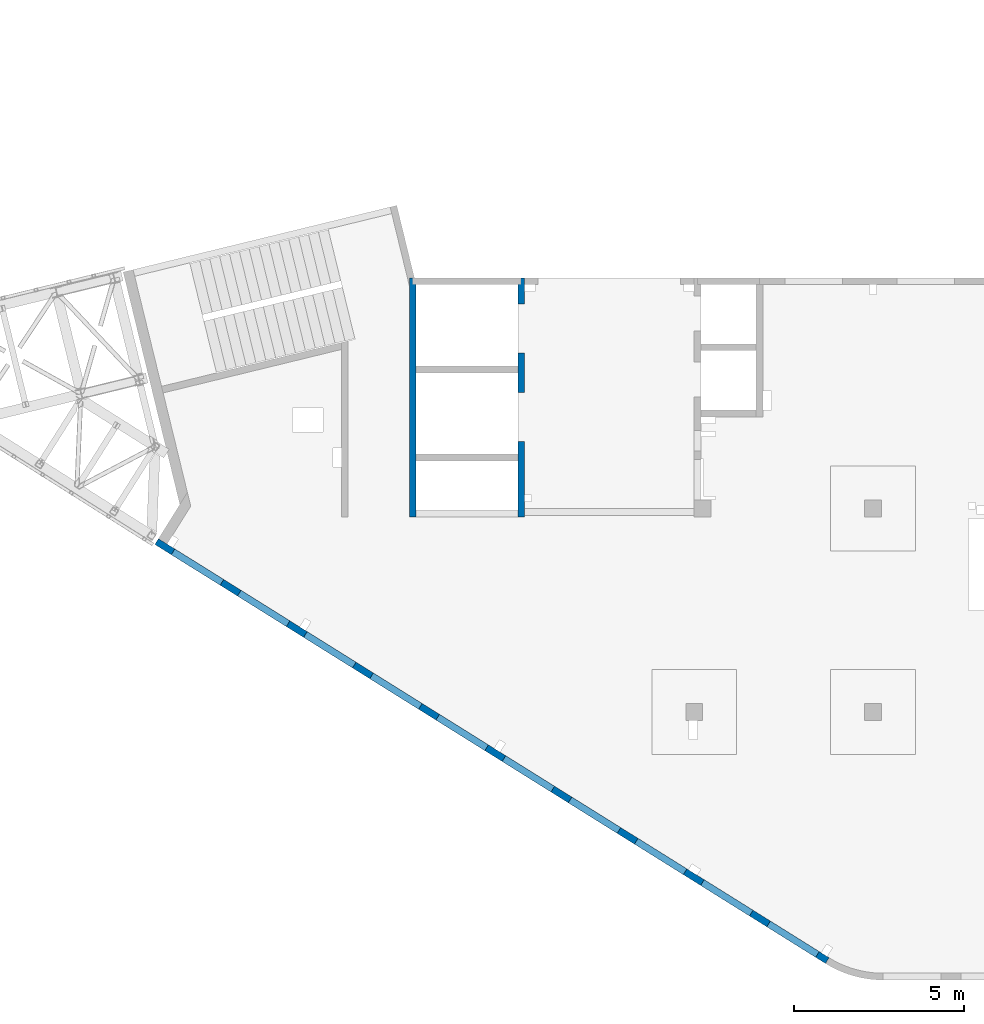
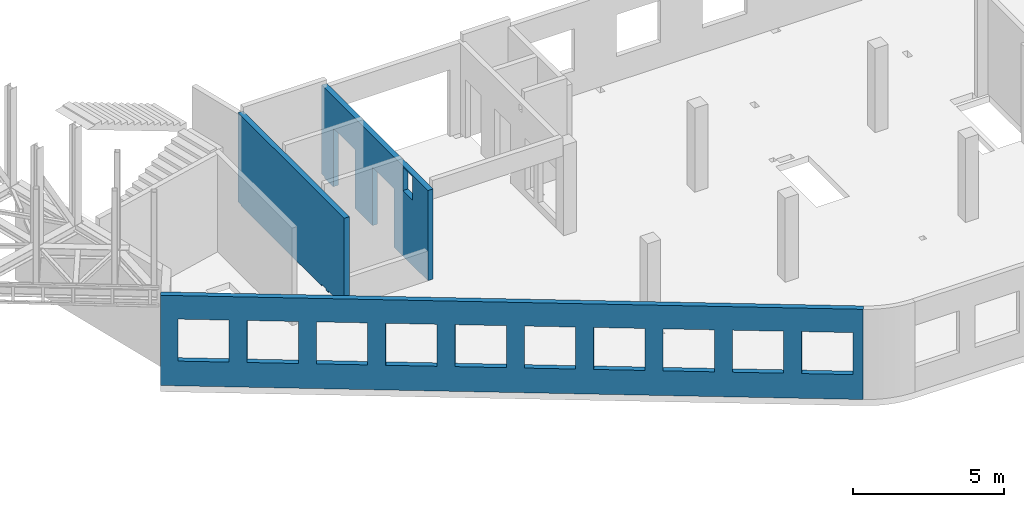
# One storey, part 89 of 93: 3 walls, 15 openings.
"""IFC4 building model written with IfcOpenShell, lengths in millimetres."""

from ifc_helpers import new_model, entity, si_unit, converted_unit, derived_unit, direction, frame, origin, place, context, subcontext, project, spatial, indexed_curve, outline, extrude, polygons, material, type_object, element, save


model = new_model("IFC4")

# Units and contexts
model_context = context("Model", 3, precision=0.01, world=origin(), true_north=direction((6.12303176911189e-17, 1.0)))
plan_context = context("Plan", 3, precision=0.01, world=origin(), true_north=direction((6.12303176911189e-17, 1.0)))
body_context = subcontext(model_context, "Body", "Model", "MODEL_VIEW")
ifc_project = project(units=[si_unit("LENGTHUNIT", "METRE", prefix="MILLI"), si_unit("AREAUNIT", "SQUARE_METRE"), si_unit("VOLUMEUNIT", "CUBIC_METRE"), converted_unit("PLANEANGLEUNIT", "DEGREE", entity("IfcRatioMeasure", 0.0174532925199433), si_unit("PLANEANGLEUNIT", "RADIAN"), dimensions=[0, 0, 0, 0, 0, 0, 0]), si_unit("MASSUNIT", "GRAM", prefix="KILO"), derived_unit("MASSDENSITYUNIT", [(si_unit("MASSUNIT", "GRAM", prefix="KILO"), 1), (si_unit("LENGTHUNIT", "METRE"), -3)]), derived_unit("MOMENTOFINERTIAUNIT", [(si_unit("LENGTHUNIT", "METRE"), 4)]), si_unit("TIMEUNIT", "SECOND"), si_unit("FREQUENCYUNIT", "HERTZ"), si_unit("THERMODYNAMICTEMPERATUREUNIT", "DEGREE_CELSIUS"), derived_unit("THERMALTRANSMITTANCEUNIT", [(si_unit("MASSUNIT", "GRAM", prefix="KILO"), 1), (si_unit("THERMODYNAMICTEMPERATUREUNIT", "KELVIN"), -1), (si_unit("TIMEUNIT", "SECOND"), -3)]), derived_unit("VOLUMETRICFLOWRATEUNIT", [(si_unit("LENGTHUNIT", "METRE"), 3), (si_unit("TIMEUNIT", "SECOND"), -1)]), derived_unit("MASSFLOWRATEUNIT", [(si_unit("MASSUNIT", "GRAM", prefix="KILO"), 1), (si_unit("TIMEUNIT", "SECOND"), -1)]), derived_unit("ROTATIONALFREQUENCYUNIT", [(si_unit("TIMEUNIT", "SECOND"), -1)]), si_unit("ELECTRICCURRENTUNIT", "AMPERE"), si_unit("ELECTRICVOLTAGEUNIT", "VOLT"), si_unit("POWERUNIT", "WATT"), si_unit("FORCEUNIT", "NEWTON", prefix="KILO"), si_unit("ILLUMINANCEUNIT", "LUX"), si_unit("LUMINOUSFLUXUNIT", "LUMEN"), si_unit("LUMINOUSINTENSITYUNIT", "CANDELA"), derived_unit("USERDEFINED", [(si_unit("MASSUNIT", "GRAM", prefix="KILO"), -1), (si_unit("LENGTHUNIT", "METRE"), -2), (si_unit("TIMEUNIT", "SECOND"), 3), (si_unit("LUMINOUSFLUXUNIT", "LUMEN"), 1)]), derived_unit("LINEARVELOCITYUNIT", [(si_unit("LENGTHUNIT", "METRE"), 1), (si_unit("TIMEUNIT", "SECOND"), -1)]), si_unit("PRESSUREUNIT", "PASCAL"), derived_unit("USERDEFINED", [(si_unit("LENGTHUNIT", "METRE"), -2), (si_unit("MASSUNIT", "GRAM", prefix="KILO"), 1), (si_unit("TIMEUNIT", "SECOND"), -2)]), derived_unit("LINEARFORCEUNIT", [(si_unit("MASSUNIT", "GRAM", prefix="KILO"), 1), (si_unit("LENGTHUNIT", "METRE"), 1), (si_unit("TIMEUNIT", "SECOND"), -2), (si_unit("LENGTHUNIT", "METRE"), -1)]), derived_unit("PLANARFORCEUNIT", [(si_unit("MASSUNIT", "GRAM", prefix="KILO"), 1), (si_unit("LENGTHUNIT", "METRE"), 1), (si_unit("TIMEUNIT", "SECOND"), -2), (si_unit("LENGTHUNIT", "METRE"), -2)])], contexts=[model_context, plan_context])

# Site, building, storey
site_placement = place(None, origin())
site = spatial("IfcSite", under=ifc_project, at=site_placement, CompositionType="ELEMENT")
building_placement = place(site_placement, origin())
building = spatial("IfcBuilding", under=site, at=building_placement, CompositionType="ELEMENT")
storey_placement = place(building_placement, frame((0.0, 0.0, 15900.0)))
storey = spatial("IfcBuildingStorey", under=building, at=storey_placement, CompositionType="ELEMENT", Elevation=15900.0)

# Wall, openings
ifc_material = material()
wall_type = type_object("IfcWallType", PredefinedType="STANDARD")
wall_1_placement = place(storey_placement, frame((19822.3508929728, 371.159406986362, -150.0), z_axis=(0.0, 0.0, 1.0), x_axis=(-0.848052743777574, 0.529911826412025, 0.0)))
wall_1 = element("IfcWall", 1, at=wall_1_placement, inside=storey, type_object=wall_type, material=ifc_material, PredefinedType="NOTDEFINED", context=body_context, shape_type="Tessellation", body=[
    polygons([(-1.48894230278529e-12, -99.9999999999978, -2.16573425859679e-12), (23011.6394501553, -99.9999999999989, 0.0), (23311.6394501553, -99.9999999999989, -2.16573425859679e-12), (23311.6394501553, -99.9999999999989, 2400.0), (23311.6394501553, -99.9999999999989, 3300.0), (23311.6394501553, -99.9999999999989, 3650.0), (23011.6394501553, -99.9999999999989, 3650.0), (-1.48894230278529e-12, -99.9999999999978, 3650.0), (341.63903172165, -99.9999999999988, 2700.0), (2041.63903172165, -99.9999999999981, 2700.0), (2041.63903172165, -99.9999999999981, 1000.00000000001), (341.63903172165, -99.9999999999988, 1000.00000000001), (2641.63903172165, -99.9999999999995, 2700.0), (4341.63903172165, -99.9999999999992, 2700.0), (4341.63903172165, -99.9999999999992, 1000.00000000001), (2641.63903172165, -99.9999999999995, 1000.00000000001), (4941.63903172166, -100.0, 2700.0), (6641.63903172166, -99.9999999999984, 2700.0), (6641.63903172166, -99.9999999999984, 1000.00000000001), (4941.63903172166, -100.0, 1000.00000000001), (7241.63903172167, -99.9999999999984, 2700.0), (8941.63903172167, -100.0, 2700.0), (8941.63903172167, -100.0, 1000.00000000001), (7241.63903172167, -99.9999999999984, 1000.00000000001), (9541.63903172167, -100.0, 2700.0), (11241.6390317217, -99.9999999999989, 2700.0), (11241.6390317217, -99.9999999999989, 1000.00000000001), (9541.63903172167, -100.0, 1000.00000000001), (11841.6390317217, -100.0, 2700.0), (13541.6390317217, -100.0, 2700.0), (13541.6390317217, -100.0, 1000.00000000001), (11841.6390317217, -100.0, 1000.00000000001), (14141.6390317217, -100.0, 2700.0), (15841.6390317217, -100.0, 2700.0), (15841.6390317217, -100.0, 1000.00000000001), (14141.6390317217, -100.0, 1000.00000000001), (16441.6390317217, -99.9999999999989, 2700.0), (18141.6390317217, -99.9999999999989, 2700.0), (18141.6390317217, -99.9999999999989, 1000.00000000001), (16441.6390317217, -99.9999999999989, 1000.00000000001), (18741.6390317217, -100.0, 2700.0), (20441.6390317217, -99.9999999999989, 2700.0), (20441.6390317217, -99.9999999999989, 1000.00000000001), (18741.6390317217, -100.0, 1000.00000000001), (21041.6390317217, -99.9999999999989, 2700.0), (22741.6390317217, -100.000000000001, 2700.0), (22741.6390317217, -100.000000000001, 1000.00000000001), (21041.6390317217, -99.9999999999989, 1000.00000000001), (23311.6394501553, 99.9999999999989, -2.16573425859679e-12), (-2.26725305196851e-12, 100.000000000001, -2.16573425859679e-12), (-2.26725305196851e-12, 100.000000000001, 3650.0), (23311.6394501553, 100.000000000001, 3650.0), (23311.6394501553, 100.000000000001, 3300.0), (23311.6394501553, 100.000000000001, 2400.0), (2041.63903172165, 100.000000000323, 2700.0), (341.63903172165, 100.000000000321, 2700.0), (341.63903172165, 100.000000000321, 1000.00000000001), (2041.63903172165, 100.000000000323, 1000.00000000001), (4341.63903172165, 100.000000000322, 2700.0), (2641.63903172165, 100.00000000032, 2700.0), (2641.63903172165, 100.00000000032, 1000.00000000001), (4341.63903172165, 100.000000000322, 1000.00000000001), (6641.63903172166, 100.000000000322, 2700.0), (4941.63903172166, 100.000000000321, 2700.0), (4941.63903172166, 100.000000000321, 1000.00000000001), (6641.63903172166, 100.000000000322, 1000.00000000001), (8941.63903172166, 100.000000000321, 2700.0), (7241.63903172167, 100.000000000322, 2700.0), (7241.63903172167, 100.000000000322, 1000.00000000001), (8941.63903172166, 100.000000000321, 1000.00000000001), (11241.6390317217, 100.000000000323, 2700.0), (9541.63903172167, 100.000000000321, 2700.0), (9541.63903172167, 100.000000000321, 1000.00000000001), (11241.6390317217, 100.000000000323, 1000.00000000001), (13541.6390317217, 100.000000000319, 2700.0), (11841.6390317217, 100.000000000323, 2700.0), (11841.6390317217, 100.000000000323, 1000.00000000001), (13541.6390317217, 100.000000000319, 1000.00000000001), (15841.6390317217, 100.000000000322, 2700.0), (14141.6390317217, 100.000000000322, 2700.0), (14141.6390317217, 100.000000000322, 1000.00000000001), (15841.6390317217, 100.000000000322, 1000.00000000001), (18141.6390317217, 100.000000000322, 2700.0), (16441.6390317217, 100.000000000322, 2700.0), (16441.6390317217, 100.000000000322, 1000.00000000001), (18141.6390317217, 100.000000000322, 1000.00000000001), (20441.6390317217, 100.000000000322, 2700.0), (18741.6390317217, 100.000000000319, 2700.0), (18741.6390317217, 100.000000000319, 1000.00000000001), (20441.6390317217, 100.000000000322, 1000.00000000001), (22741.6390317217, 100.000000000319, 2700.0), (21041.6390317217, 100.000000000321, 2700.0), (21041.6390317217, 100.000000000323, 1000.00000000001), (22741.6390317217, 100.000000000319, 1000.00000000001)], [[[1, 2, 3, 4, 5, 6, 7, 8], [9, 10, 11, 12], [13, 14, 15, 16], [17, 18, 19, 20], [21, 22, 23, 24], [25, 26, 27, 28], [29, 30, 31, 32], [33, 34, 35, 36], [37, 38, 39, 40], [41, 42, 43, 44], [45, 46, 47, 48]], [[49, 50, 51, 52, 53, 54], [55, 56, 57, 58], [59, 60, 61, 62], [63, 64, 65, 66], [67, 68, 69, 70], [71, 72, 73, 74], [75, 76, 77, 78], [79, 80, 81, 82], [83, 84, 85, 86], [87, 88, 89, 90], [91, 92, 93, 94]], [[3, 2, 1, 50, 49]], [[8, 7, 6, 52, 51]], [[1, 8, 51, 50]], [[3, 49, 54, 53, 52, 6, 5, 4]], [[56, 55, 10, 9]], [[56, 9, 12, 57]], [[57, 12, 11, 58]], [[10, 55, 58, 11]], [[60, 59, 14, 13]], [[60, 13, 16, 61]], [[61, 16, 15, 62]], [[14, 59, 62, 15]], [[64, 63, 18, 17]], [[64, 17, 20, 65]], [[65, 20, 19, 66]], [[18, 63, 66, 19]], [[68, 67, 22, 21]], [[68, 21, 24, 69]], [[69, 24, 23, 70]], [[22, 67, 70, 23]], [[72, 71, 26, 25]], [[72, 25, 28, 73]], [[73, 28, 27, 74]], [[26, 71, 74, 27]], [[76, 75, 30, 29]], [[76, 29, 32, 77]], [[77, 32, 31, 78]], [[30, 75, 78, 31]], [[80, 79, 34, 33]], [[80, 33, 36, 81]], [[81, 36, 35, 82]], [[34, 79, 82, 35]], [[84, 83, 38, 37]], [[84, 37, 40, 85]], [[85, 40, 39, 86]], [[38, 83, 86, 39]], [[88, 87, 42, 41]], [[88, 41, 44, 89]], [[89, 44, 43, 90]], [[42, 87, 90, 43]], [[92, 91, 46, 45]], [[92, 45, 48, 93]], [[93, 48, 47, 94]], [[46, 91, 94, 47]]], closed=True),
])
opening_1_placement = place(wall_1_placement, frame((16613.7173036613, 10818.8609189489, 150.0), z_axis=(0.0, 0.0, 1.0), x_axis=(-0.848052743777574, -0.529911826412026, 0.0)))
element("IfcOpeningElement", 2, at=opening_1_placement, cuts=wall_1, PredefinedType="OPENING", context=body_context, shape_type="SweptSolid", body=[
    extrude(outline(indexed_curve([(-849.999999999993, -850.0), (849.999999999995, -850.0), (849.999999999995, 850.0), (-849.999999999993, 850.0), (-849.999999999993, -850.0)], self_intersect=False)), frame((1310.07752897417, 12056.6031038165, 1700.0), z_axis=(-0.529911826412026, -0.848052743777574, 0.0), x_axis=(0.0, 0.0, -1.0)), (0.0, 0.0, 1.0), 200.000000000964),
])
opening_2_placement = place(wall_1_placement, frame((16613.7173036613, 10818.8609189489, 150.0), z_axis=(0.0, 0.0, 1.0), x_axis=(-0.848052743777574, -0.529911826412026, 0.0)))
element("IfcOpeningElement", 3, at=opening_2_placement, cuts=wall_1, PredefinedType="OPENING", context=body_context, shape_type="SweptSolid", body=[
    extrude(outline(indexed_curve([(-849.999999999993, -850.0), (849.999999999995, -850.0), (849.999999999995, 850.0), (-849.999999999993, 850.0), (-849.999999999993, -850.0)], self_intersect=False)), frame((3260.5988396626, 10837.8059030689, 1700.0), z_axis=(-0.529911826412026, -0.848052743777574, 0.0), x_axis=(0.0, 0.0, -1.0)), (0.0, 0.0, 1.0), 200.000000000964),
])
opening_3_placement = place(wall_1_placement, frame((16613.7173036613, 10818.8609189489, 150.0), z_axis=(0.0, 0.0, 1.0), x_axis=(-0.848052743777574, -0.529911826412026, 0.0)))
element("IfcOpeningElement", 4, at=opening_3_placement, cuts=wall_1, PredefinedType="OPENING", context=body_context, shape_type="SweptSolid", body=[
    extrude(outline(indexed_curve([(-849.999999999993, -850.0), (849.999999999995, -850.0), (849.999999999995, 850.0), (-849.999999999993, 850.0), (-849.999999999993, -850.0)], self_intersect=False)), frame((5211.12015035101, 9619.00870232123, 1700.0), z_axis=(-0.529911826412025, -0.848052743777574, 0.0), x_axis=(0.0, 0.0, -1.0)), (0.0, 0.0, 1.0), 200.000000000962),
])
opening_4_placement = place(wall_1_placement, frame((16613.7173036613, 10818.8609189489, 150.0), z_axis=(0.0, 0.0, 1.0), x_axis=(-0.848052743777574, -0.529911826412026, 0.0)))
element("IfcOpeningElement", 5, at=opening_4_placement, cuts=wall_1, PredefinedType="OPENING", context=body_context, shape_type="SweptSolid", body=[
    extrude(outline(indexed_curve([(-849.999999999993, -849.999999999999), (849.999999999995, -849.999999999999), (849.999999999995, 850.0), (-849.999999999993, 850.0), (-849.999999999993, -849.999999999999)], self_intersect=False)), frame((7161.64146103944, 8400.21150157357, 1700.0), z_axis=(-0.529911826412026, -0.848052743777574, 0.0), x_axis=(0.0, 0.0, -1.0)), (0.0, 0.0, 1.0), 200.000000000962),
])
opening_5_placement = place(wall_1_placement, frame((16613.7173036613, 10818.8609189489, 150.0), z_axis=(0.0, 0.0, 1.0), x_axis=(-0.848052743777574, -0.529911826412026, 0.0)))
element("IfcOpeningElement", 6, at=opening_5_placement, cuts=wall_1, PredefinedType="OPENING", context=body_context, shape_type="SweptSolid", body=[
    extrude(outline(indexed_curve([(-849.999999999993, -849.999999999999), (849.999999999995, -849.999999999999), (849.999999999995, 850.0), (-849.999999999993, 850.0), (-849.999999999993, -849.999999999999)], self_intersect=False)), frame((9112.16277172786, 7181.41430082591, 1700.0), z_axis=(-0.529911826412026, -0.848052743777574, 0.0), x_axis=(0.0, 0.0, -1.0)), (0.0, 0.0, 1.0), 200.000000000962),
])
opening_6_placement = place(wall_1_placement, frame((16613.7173036613, 10818.8609189489, 150.0), z_axis=(0.0, 0.0, 1.0), x_axis=(-0.848052743777574, -0.529911826412026, 0.0)))
element("IfcOpeningElement", 7, at=opening_6_placement, cuts=wall_1, PredefinedType="OPENING", context=body_context, shape_type="SweptSolid", body=[
    extrude(outline(indexed_curve([(-849.999999999993, -850.0), (849.999999999995, -850.0), (849.999999999995, 850.0), (-849.999999999993, 850.0), (-849.999999999993, -850.0)], self_intersect=False)), frame((11062.6840824163, 5962.61710007824, 1700.0), z_axis=(-0.529911826412025, -0.848052743777574, 0.0), x_axis=(0.0, 0.0, -1.0)), (0.0, 0.0, 1.0), 200.000000000964),
])
opening_7_placement = place(wall_1_placement, frame((16613.7173036613, 10818.8609189489, 150.0), z_axis=(0.0, 0.0, 1.0), x_axis=(-0.848052743777574, -0.529911826412026, 0.0)))
element("IfcOpeningElement", 8, at=opening_7_placement, cuts=wall_1, PredefinedType="OPENING", context=body_context, shape_type="SweptSolid", body=[
    extrude(outline(indexed_curve([(-849.999999999993, -850.0), (849.999999999995, -850.0), (849.999999999995, 850.0), (-849.999999999993, 850.0), (-849.999999999993, -850.0)], self_intersect=False)), frame((13013.2053931047, 4743.81989933058, 1700.0), z_axis=(-0.529911826412025, -0.848052743777574, 0.0), x_axis=(0.0, 0.0, -1.0)), (0.0, 0.0, 1.0), 200.000000000959),
])
opening_8_placement = place(wall_1_placement, frame((16613.7173036613, 10818.8609189489, 150.0), z_axis=(0.0, 0.0, 1.0), x_axis=(-0.848052743777574, -0.529911826412026, 0.0)))
element("IfcOpeningElement", 9, at=opening_8_placement, cuts=wall_1, PredefinedType="OPENING", context=body_context, shape_type="SweptSolid", body=[
    extrude(outline(indexed_curve([(-849.999999999993, -850.000000000002), (849.999999999995, -850.000000000002), (849.999999999995, 849.999999999998), (-849.999999999993, 849.999999999998), (-849.999999999993, -850.000000000002)], self_intersect=False)), frame((14963.7267037931, 3525.02269858292, 1700.0), z_axis=(-0.529911826412025, -0.848052743777574, 0.0), x_axis=(0.0, 0.0, -1.0)), (0.0, 0.0, 1.0), 200.000000000962),
])
opening_9_placement = place(wall_1_placement, frame((16613.7173036613, 10818.8609189489, 150.0), z_axis=(0.0, 0.0, 1.0), x_axis=(-0.848052743777574, -0.529911826412026, 0.0)))
element("IfcOpeningElement", 10, at=opening_9_placement, cuts=wall_1, PredefinedType="OPENING", context=body_context, shape_type="SweptSolid", body=[
    extrude(outline(indexed_curve([(-849.999999999993, -850.0), (849.999999999995, -850.0), (849.999999999995, 850.0), (-849.999999999993, 850.0), (-849.999999999993, -850.0)], self_intersect=False)), frame((16914.2480144816, 2306.22549783526, 1700.0), z_axis=(-0.529911826412025, -0.848052743777574, 0.0), x_axis=(0.0, 0.0, -1.0)), (0.0, 0.0, 1.0), 200.000000000962),
])
opening_10_placement = place(wall_1_placement, frame((16613.7173036613, 10818.8609189489, 150.0), z_axis=(0.0, 0.0, 1.0), x_axis=(-0.848052743777574, -0.529911826412026, 0.0)))
element("IfcOpeningElement", 11, at=opening_10_placement, cuts=wall_1, PredefinedType="OPENING", context=body_context, shape_type="SweptSolid", body=[
    extrude(outline(indexed_curve([(-849.999999999993, -850.0), (849.999999999995, -850.0), (849.999999999995, 850.0), (-849.999999999993, 850.0), (-849.999999999993, -850.0)], self_intersect=False)), frame((18864.76932517, 1087.4282970876, 1700.0), z_axis=(-0.529911826412025, -0.848052743777574, 0.0), x_axis=(0.0, 0.0, -1.0)), (0.0, 0.0, 1.0), 200.000000000966),
])

wall_2_placement = place(storey_placement, frame((7600.0002685547, 20499.9998657227, -150.0), z_axis=(0.0, 0.0, 1.0), x_axis=(0.0, -1.0, 0.0)))
wall_2 = element("IfcWall", 12, at=wall_2_placement, inside=storey, type_object=wall_type, material=ifc_material, PredefinedType="NOTDEFINED", context=body_context, shape_type="Tessellation", body=[
    polygons([(7050.00063936678, -99.9999999999996, 3650.0), (226.500105821614, -99.9999999999996, 3650.0), (0.0, -100.000000000001, 3650.0), (0.0, -100.000000000001, 49.9999999999995), (200.000000000002, -100.000000000001, 49.9999999999995), (200.000000000002, -100.000000000001, -2.16573425859679e-12), (226.50010582161, -99.9999999999996, 0.0), (5545.0, -100.000000000001, -2.16573425859679e-12), (5545.0, -100.000000000001, 59.9999999999972), (5855.0, -100.0, 59.9999999999972), (5855.0, -100.0, -2.16573425859679e-12), (5985.0, -100.0, -2.16573425859679e-12), (5985.0, -100.0, 59.9999999999972), (6294.99999999999, -99.9999999999997, 59.9999999999972), (6294.99999999999, -99.9999999999997, -2.16573425859679e-12), (7050.00063936678, -99.9999999999996, -2.16573425859679e-12), (0.0, 100.0, 3650.0), (6850.00063936679, 100.0, 3650.0), (7050.00063936678, 99.9999999999993, 3650.0), (7050.00063936678, 100.0, 1200.0), (7050.00063936678, 99.9999999999993, -2.16573425859679e-12), (6850.0006393668, 100.0, 0.0), (6294.99999999999, 100.0, -2.16573425859679e-12), (6294.99999999999, 100.000000000321, 59.9999999999972), (5985.0, 100.000000000321, 59.9999999999972), (5985.0, 100.000000000001, -2.16573425859679e-12), (5855.0, 100.000000000001, -2.16573425859679e-12), (5855.0, 100.000000000321, 59.9999999999972), (5545.0, 100.000000000321, 59.9999999999972), (5545.0, 100.0, -2.16573425859679e-12), (200.000000000002, 100.0, -2.16573425859679e-12), (200.000000000002, 100.0, 49.9999999999995), (0.0, 100.0, 49.9999999999995), (200.000000000002, -6.87656940234796e-13, 0.0), (0.0, 50.6443876577722, 3650.0)], [[[1, 2, 3, 4, 5, 6, 7, 8, 9, 10, 11, 12, 13, 14, 15, 16]], [[17, 18, 19, 20, 21, 22, 23, 24, 25, 26, 27, 28, 29, 30, 31, 32, 33]], [[6, 34, 31, 30, 8, 7]], [[3, 2, 1, 19, 18, 17, 35]], [[6, 5, 32, 31, 34]], [[4, 3, 35, 17, 33]], [[13, 25, 24, 14]], [[25, 13, 12, 26]], [[14, 24, 23, 15]], [[9, 29, 28, 10]], [[29, 9, 8, 30]], [[10, 28, 27, 11]], [[1, 16, 21, 20, 19]], [[33, 32, 5, 4]], [[16, 15, 23, 22, 21]], [[26, 12, 11, 27]]], closed=True),
])
opening_11_placement = place(wall_2_placement, origin())
element("IfcOpeningElement", 13, at=opening_11_placement, cuts=wall_2, PredefinedType="OPENING", context=body_context, shape_type="SweptSolid", body=[
    extrude(outline(indexed_curve([(-154.999999999995, -154.999999999999), (154.999999999991, -154.999999999999), (154.999999999991, 154.999999999999), (-154.999999999995, 154.999999999999), (-154.999999999995, -154.999999999999)], self_intersect=False)), frame((6140.0, -100.0, -95.0), z_axis=(0.0, 1.0, 0.0), x_axis=(0.0, 0.0, -1.0)), (0.0, 0.0, 1.0), 200.000000000962),
])
opening_12_placement = place(wall_2_placement, origin())
element("IfcOpeningElement", 14, at=opening_12_placement, cuts=wall_2, PredefinedType="OPENING", context=body_context, shape_type="SweptSolid", body=[
    extrude(outline(indexed_curve([(-154.999999999995, -154.999999999999), (154.999999999991, -154.999999999999), (154.999999999991, 154.999999999999), (-154.999999999995, 154.999999999999), (-154.999999999995, -154.999999999999)], self_intersect=False)), frame((5700.0, -100.0, -95.0), z_axis=(0.0, 1.0, 0.0), x_axis=(0.0, 0.0, -1.0)), (0.0, 0.0, 1.0), 200.000000000962),
])

wall_3_placement = place(storey_placement, frame((10800.0002685547, 20499.9998657227, -150.0), z_axis=(0.0, 0.0, 1.0), x_axis=(0.0, -1.0, 0.0)))
wall_3 = element("IfcWall", 15, at=wall_3_placement, inside=storey, type_object=wall_type, material=ifc_material, PredefinedType="NOTDEFINED", context=body_context, shape_type="Tessellation", body=[
    polygons([(5400.00000000002, -99.999999999999, 3600.0), (6050.00000000002, -99.9999999999979, 3600.0), (6050.00000000002, -99.9999999999979, 2650.00000000002), (5400.00000000002, -99.999999999999, 2650.00000000002), (7050.00063936681, -99.9999999999985, 3650.0), (6850.00063936682, -99.9999999999988, 3650.0), (200.000000000028, -99.9999999999985, 3650.0), (0.0, -99.9999999999988, 3650.0), (0.0, -99.9999999999988, 49.9999999999995), (200.000000000028, -99.9999999999985, 49.9999999999995), (200.000000000028, -99.9999999999985, -2.16573425859679e-12), (780.000000000018, -99.9999999999976, -2.16573425859679e-12), (780.000000000018, -99.9999999999976, 2369.99999999805), (2220.00000000001, -99.9999999999975, 2369.99999999804), (2220.00000000001, -99.9999999999975, -2.16573425859679e-12), (3380.00000000002, -99.9999999999978, -2.16573425859679e-12), (3380.00000000002, -99.9999999999978, 2369.99999999805), (4820.00000000001, -99.9999999999977, 2369.99999999805), (4820.00000000001, -99.9999999999977, -2.16573425859679e-12), (6850.00063936681, -99.9999999999988, 0.0), (7050.00063936681, -99.9999999999985, -2.16573425859679e-12), (7050.00063936681, -99.9999999999985, 1200.0), (0.0, 100.000000000001, 3650.0), (200.000000000002, 100.000000000001, 3650.0), (399.999999999983, 100.000000000002, 3650.0), (6400.00063936681, 100.0, 3650.0), (6600.00063936681, 100.000000000001, 3650.0), (7050.00063936681, 100.000000000001, 3650.0), (7050.00063936681, 100.000000000001, -2.16573425859679e-12), (6600.00063936682, 100.000000000001, 0.0), (6400.00063936682, 100.0, 0.0), (4820.00000000001, 100.000000000002, -2.16573425859679e-12), (4820.00000000002, 100.000000000002, 2369.99999999805), (3380.00000000002, 100.000000000002, 2369.99999999804), (3380.00000000002, 100.000000000002, -2.16573425859679e-12), (2220.00000000001, 100.000000000003, -2.16573425859679e-12), (2220.00000000001, 100.000000000003, 2369.99999999805), (780.000000000018, 100.000000000002, 2369.99999999805), (780.000000000018, 100.000000000002, -2.16573425859679e-12), (400.00000000003, 100.000000000002, 0.0), (200.000000000028, 100.000000000001, -2.16573425859679e-12), (200.000000000028, 100.000000000001, 49.9999999999995), (0.0, 100.000000000001, 49.9999999999995), (6050.00000000002, 100.000000000323, 3600.0), (5400.00000000002, 100.000000000322, 3600.0), (5400.00000000002, 100.000000000322, 2650.00000000002), (6050.00000000002, 100.000000000323, 2650.00000000002), (0.0, -2.0866896252195e-12, 3650.0), (200.000000000028, 3.95210189063612e-13, 49.9999999999973), (0.0, 7.90446333772861e-14, 49.9999999999973)], [[[5, 6, 7, 8, 9, 10, 11, 12, 13, 14, 15, 16, 17, 18, 19, 20, 21, 22], [1, 2, 3, 4]], [[23, 24, 25, 26, 27, 28, 29, 30, 31, 32, 33, 34, 35, 36, 37, 38, 39, 40, 41, 42, 43], [44, 45, 46, 47]], [[12, 11, 41, 40, 39]], [[8, 7, 6, 5, 28, 27, 26, 25, 24, 23, 48]], [[45, 44, 2, 1]], [[45, 1, 4, 46]], [[46, 4, 3, 47]], [[2, 44, 47, 3]], [[13, 38, 37, 14]], [[14, 37, 36, 15]], [[38, 13, 12, 39]], [[33, 18, 17, 34]], [[34, 17, 16, 35]], [[18, 33, 32, 19]], [[43, 42, 49, 10, 9, 50]], [[11, 10, 49, 42, 41]], [[43, 50, 9, 8, 48, 23]], [[5, 22, 21, 29, 28]], [[15, 36, 35, 16]], [[29, 21, 20, 19, 32, 31, 30]]], closed=True),
])
opening_13_placement = place(wall_3_placement, frame((20499.9998657227, -10800.0002685547, 150.0), z_axis=(0.0, 0.0, 1.0), x_axis=(0.0, 1.0, 0.0)))
element("IfcOpeningElement", 16, at=opening_13_placement, cuts=wall_3, PredefinedType="OPENING", context=body_context, shape_type="SweptSolid", body=[
    extrude(outline(indexed_curve([(-719.999999999999, -1184.99999999902), (719.999999999999, -1184.99999999902), (719.999999999999, 1184.99999999902), (-719.999999999999, 1184.99999999902), (-719.999999999999, -1184.99999999902)], self_intersect=False)), frame((10600.0002685528, 18999.9998657227, 1035.0), z_axis=(1.0, 0.0, 0.0), x_axis=(0.0, -1.0, 0.0)), (0.0, 0.0, 1.0), 400.000000001943),
])
opening_14_placement = place(wall_3_placement, frame((20499.9998657227, -10800.0002685547, 150.0), z_axis=(0.0, 0.0, 1.0), x_axis=(0.0, 1.0, 0.0)))
element("IfcOpeningElement", 17, at=opening_14_placement, cuts=wall_3, PredefinedType="OPENING", context=body_context, shape_type="SweptSolid", body=[
    extrude(outline(indexed_curve([(-1184.99999999902, -719.999999999999), (1184.99999999902, -719.999999999999), (1184.99999999902, 720.000000000001), (-1184.99999999902, 720.000000000001), (-1184.99999999902, -719.999999999999)], self_intersect=False)), frame((10600.0002685547, 16399.9998657227, 1035.0), z_axis=(1.0, 0.0, 0.0), x_axis=(0.0, 0.0, -1.0)), (0.0, 0.0, 1.0), 400.000000001943),
])
opening_15_placement = place(wall_3_placement, frame((20499.9998657227, -10800.0002685547, 150.0), z_axis=(0.0, 0.0, 1.0), x_axis=(0.0, 1.0, 0.0)))
element("IfcOpeningElement", 18, at=opening_15_placement, cuts=wall_3, PredefinedType="OPENING", context=body_context, shape_type="SweptSolid", body=[
    extrude(outline(indexed_curve([(-474.999999999994, -325.0), (474.999999999992, -325.0), (474.999999999992, 325.0), (-474.999999999994, 325.0), (-474.999999999994, -325.0)], self_intersect=False)), frame((10700.0002685547, 14774.9998657227, 2975.0), z_axis=(1.0, 0.0, 0.0), x_axis=(0.0, 0.0, -1.0)), (0.0, 0.0, 1.0), 200.000000000962),
])

save(model, "model.ifc")
